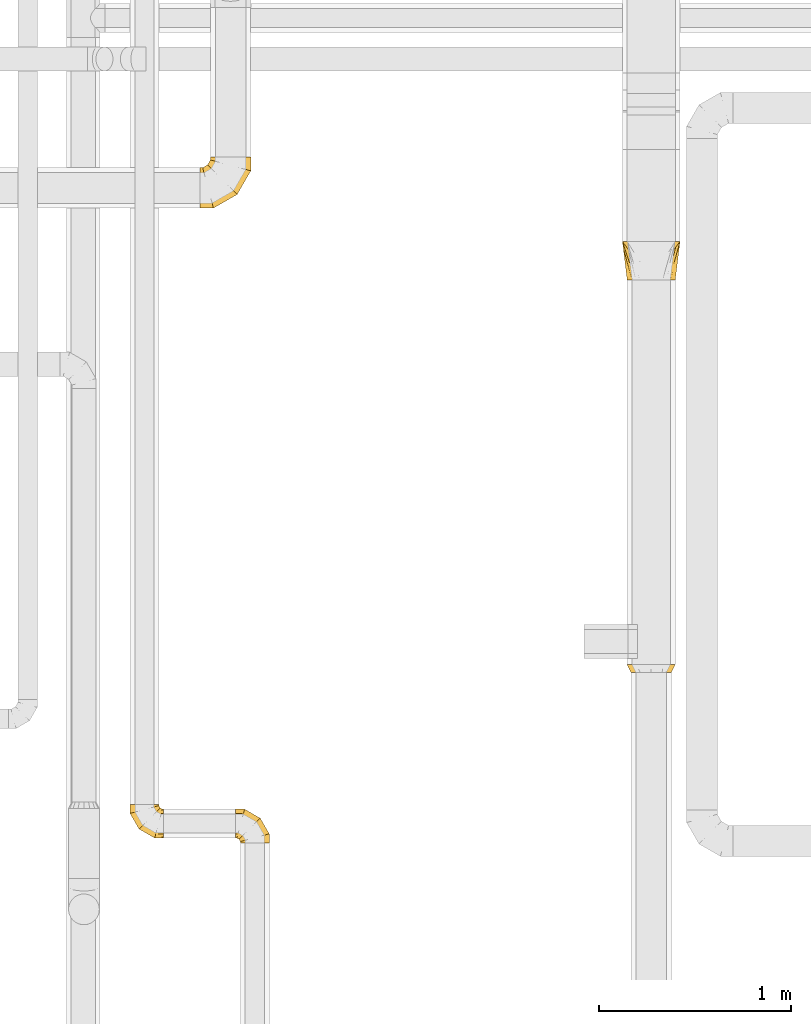
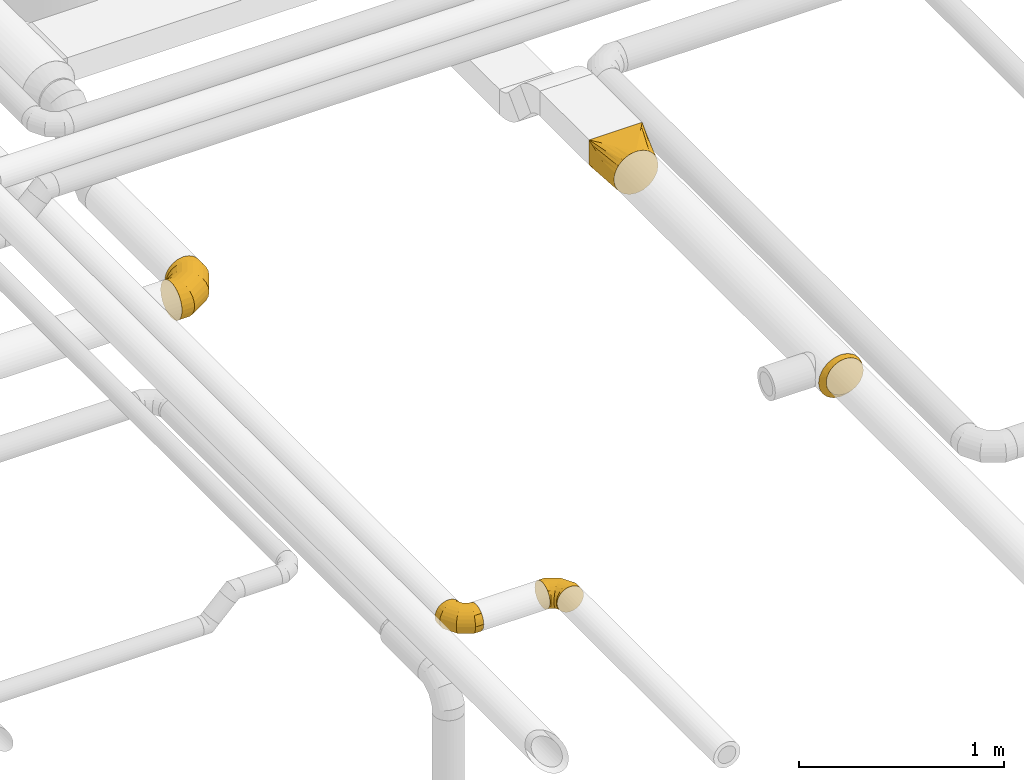
# One storey, part 20 of 92: 5 coverings.
"""IFC2X3 building model written with IfcOpenShell, lengths in millimetres."""

from ifc_helpers import new_model, entity, si_unit, converted_unit, derived_unit, direction, frame, origin, place, context, subcontext, project, spatial, faceted_brep, element, save


model = new_model("IFC2X3")

# Units and contexts
model_context = context("Model", 3, precision=0.01, world=origin(), true_north=direction((6.12303176911189e-17, 1.0)))
body_context = subcontext(model_context, "Body", "Model", "MODEL_VIEW")
ifc_project = project(units=[si_unit("LENGTHUNIT", "METRE", prefix="MILLI"), si_unit("AREAUNIT", "SQUARE_METRE"), si_unit("VOLUMEUNIT", "CUBIC_METRE"), converted_unit("PLANEANGLEUNIT", "DEGREE", entity("IfcRatioMeasure", 0.0174532925199433), si_unit("PLANEANGLEUNIT", "RADIAN"), dimensions=[0, 0, 0, 0, 0, 0, 0]), si_unit("MASSUNIT", "GRAM", prefix="KILO"), derived_unit("MASSDENSITYUNIT", [(si_unit("MASSUNIT", "GRAM", prefix="KILO"), 1), (si_unit("LENGTHUNIT", "METRE"), -3)]), derived_unit("MOMENTOFINERTIAUNIT", [(si_unit("LENGTHUNIT", "METRE"), 4)]), si_unit("TIMEUNIT", "SECOND"), si_unit("FREQUENCYUNIT", "HERTZ"), si_unit("THERMODYNAMICTEMPERATUREUNIT", "DEGREE_CELSIUS"), derived_unit("THERMALTRANSMITTANCEUNIT", [(si_unit("MASSUNIT", "GRAM", prefix="KILO"), 1), (si_unit("THERMODYNAMICTEMPERATUREUNIT", "KELVIN"), -1), (si_unit("TIMEUNIT", "SECOND"), -3)]), derived_unit("VOLUMETRICFLOWRATEUNIT", [(si_unit("LENGTHUNIT", "METRE"), 3), (si_unit("TIMEUNIT", "SECOND"), -1)]), derived_unit("MASSFLOWRATEUNIT", [(si_unit("MASSUNIT", "GRAM", prefix="KILO"), 1), (si_unit("TIMEUNIT", "SECOND"), -1)]), derived_unit("ROTATIONALFREQUENCYUNIT", [(si_unit("TIMEUNIT", "SECOND"), -1)]), si_unit("ELECTRICCURRENTUNIT", "AMPERE"), si_unit("ELECTRICVOLTAGEUNIT", "VOLT"), si_unit("POWERUNIT", "WATT"), si_unit("FORCEUNIT", "NEWTON", prefix="KILO"), si_unit("ILLUMINANCEUNIT", "LUX"), si_unit("LUMINOUSFLUXUNIT", "LUMEN"), si_unit("LUMINOUSINTENSITYUNIT", "CANDELA"), derived_unit("USERDEFINED", [(si_unit("MASSUNIT", "GRAM", prefix="KILO"), -1), (si_unit("LENGTHUNIT", "METRE"), -2), (si_unit("TIMEUNIT", "SECOND"), 3), (si_unit("LUMINOUSFLUXUNIT", "LUMEN"), 1)]), derived_unit("LINEARVELOCITYUNIT", [(si_unit("LENGTHUNIT", "METRE"), 1), (si_unit("TIMEUNIT", "SECOND"), -1)]), si_unit("PRESSUREUNIT", "PASCAL"), derived_unit("USERDEFINED", [(si_unit("LENGTHUNIT", "METRE"), -2), (si_unit("MASSUNIT", "GRAM", prefix="KILO"), 1), (si_unit("TIMEUNIT", "SECOND"), -2)]), derived_unit("LINEARFORCEUNIT", [(si_unit("MASSUNIT", "GRAM", prefix="KILO"), 1), (si_unit("LENGTHUNIT", "METRE"), 1), (si_unit("TIMEUNIT", "SECOND"), -2), (si_unit("LENGTHUNIT", "METRE"), -1)]), derived_unit("PLANARFORCEUNIT", [(si_unit("MASSUNIT", "GRAM", prefix="KILO"), 1), (si_unit("LENGTHUNIT", "METRE"), 1), (si_unit("TIMEUNIT", "SECOND"), -2), (si_unit("LENGTHUNIT", "METRE"), -2)])], contexts=[model_context])

# Site, building, storey
site_placement = place(None, origin())
site = spatial("IfcSite", under=ifc_project, at=site_placement, CompositionType="ELEMENT")
building_placement = place(site_placement, origin())
building = spatial("IfcBuilding", under=site, at=building_placement, CompositionType="ELEMENT")
storey_placement = place(building_placement, frame((0.0, 0.0, 4200.0)))
storey = spatial("IfcBuildingStorey", under=building, at=storey_placement, CompositionType="ELEMENT", Elevation=4200.0)

# Coverings
covering_1_placement = place(storey_placement, frame((63121.35, 7381.43, 3073.4)))
element("IfcCovering", 1, at=covering_1_placement, inside=storey, PredefinedType="INSULATION", context=body_context, shape_type="Brep", body=[
    faceted_brep([(150.0, 0.0, 251.6), (144.04, 0.0, 250.65), (138.08, 0.0, 249.71), (126.16, 0.0, 247.82), (111.37, 0.0, 245.48), (93.95, 0.0, 236.6), (76.53, 0.0, 227.72), (62.7, 0.0, 213.9), (48.87, 0.0, 200.07), (40.0, 0.0, 182.65), (31.12, 0.0, 165.22), (28.78, 0.0, 150.44), (26.89, 0.0, 138.52), (25.94, 0.0, 132.56), (25.0, 0.0, 126.6), (25.94, 0.0, 120.63), (26.89, 0.0, 114.67), (28.78, 0.0, 102.75), (31.12, 0.0, 87.97), (40.0, 0.0, 70.55), (48.87, 0.0, 53.12), (62.7, 0.0, 39.3), (76.53, 0.0, 25.47), (93.95, 0.0, 16.59), (111.37, 0.0, 7.71), (126.16, 0.0, 5.37), (138.08, 0.0, 3.48), (144.04, 0.0, 2.54), (150.0, 0.0, 1.6), (155.96, 0.0, 2.54), (161.92, 0.0, 3.48), (173.84, 0.0, 5.37), (188.63, 0.0, 7.71), (206.05, 0.0, 16.59), (223.47, 0.0, 25.47), (237.3, 0.0, 39.3), (251.13, 0.0, 53.12), (260.0, 0.0, 70.55), (268.88, 0.0, 87.97), (271.22, 0.0, 102.75), (273.11, 0.0, 114.67), (274.06, 0.0, 120.63), (275.0, 0.0, 126.6), (274.06, 0.0, 132.56), (273.11, 0.0, 138.52), (271.22, 0.0, 150.44), (268.88, 0.0, 165.22), (260.0, 0.0, 182.65), (251.13, 0.0, 200.07), (237.3, 0.0, 213.9), (223.47, 0.0, 227.72), (206.05, 0.0, 236.6), (188.63, 0.0, 245.48), (173.84, 0.0, 247.82), (161.92, 0.0, 249.71), (155.96, 0.0, 250.65), (300.0, 200.0, 251.6), (300.0, 200.0, 101.6), (0.0, 200.0, 101.6), (0.0, 200.0, 251.6), (221.91, 95.89, 49.54), (266.44, 100.0, 67.31), (280.48, 173.97, 88.58), (241.44, 121.91, 62.55), (260.96, 147.94, 75.57), (158.99, 11.99, 7.59), (167.98, 23.97, 13.58), (185.96, 47.94, 25.57), (203.94, 71.91, 37.55), (293.49, 147.94, 108.1), (290.24, 121.91, 111.36), (286.99, 95.89, 114.61), (283.99, 71.91, 117.61), (280.99, 47.94, 120.6), (278.0, 23.97, 123.6), (276.5, 11.99, 125.1), (296.75, 173.97, 104.85), (296.75, 173.97, 235.33), (293.49, 147.94, 219.06), (290.24, 121.91, 202.79), (286.99, 95.89, 186.52), (283.99, 71.91, 171.54), (280.99, 47.94, 156.56), (278.0, 23.97, 141.58), (276.5, 11.99, 134.09), (271.79, 100.0, 230.53), (260.96, 147.94, 251.6), (241.44, 121.91, 251.6), (221.91, 95.89, 251.6), (203.94, 71.91, 251.6), (185.96, 47.94, 251.6), (167.98, 23.97, 251.6), (158.99, 11.99, 251.6), (280.48, 173.97, 251.6), (19.52, 173.97, 251.6), (39.04, 147.94, 251.6), (58.56, 121.91, 251.6), (78.09, 95.89, 251.6), (96.06, 71.91, 251.6), (114.04, 47.94, 251.6), (132.02, 23.97, 251.6), (141.01, 11.99, 251.6), (33.56, 100.0, 235.88), (6.51, 147.94, 219.06), (9.76, 121.91, 202.79), (13.01, 95.89, 186.52), (16.01, 71.91, 171.54), (19.01, 47.94, 156.56), (22.0, 23.97, 141.58), (23.5, 11.99, 134.09), (3.25, 173.97, 235.33), (3.25, 173.97, 104.85), (6.51, 147.94, 108.1), (9.76, 121.91, 111.36), (13.01, 95.89, 114.61), (16.01, 71.91, 117.61), (19.01, 47.94, 120.6), (22.0, 23.97, 123.6), (23.5, 11.99, 125.1), (28.21, 100.0, 72.66), (39.04, 147.94, 75.57), (58.56, 121.91, 62.55), (78.09, 95.89, 49.54), (96.06, 71.91, 37.55), (114.04, 47.94, 25.57), (132.02, 23.97, 13.58), (141.01, 11.99, 7.59), (19.52, 173.97, 88.58)], [[[0, 1, 2, 3, 4, 5, 6, 7, 8, 9, 10, 11, 12, 13, 14, 15, 16, 17, 18, 19, 20, 21, 22, 23, 24, 25, 26, 27, 28, 29, 30, 31, 32, 33, 34, 35, 36, 37, 38, 39, 40, 41, 42, 43, 44, 45, 46, 47, 48, 49, 50, 51, 52, 53, 54, 55]], [[56, 57, 58, 59]], [[60, 33, 32]], [[57, 61, 62]], [[33, 60, 63, 64]], [[65, 66, 67, 68, 60, 32, 31, 30, 29, 28]], [[62, 61, 34]], [[37, 69, 70, 71]], [[64, 34, 33]], [[38, 71, 72, 73, 74, 75, 42, 41, 40, 39]], [[36, 76, 69]], [[71, 38, 37]], [[61, 76, 35]], [[34, 64, 62]], [[76, 36, 35]], [[34, 61, 35]], [[61, 57, 76]], [[69, 37, 36]], [[57, 56, 77, 78, 79, 80, 81, 82, 83, 84, 42, 75, 74, 73, 72, 71, 70, 69, 76]], [[80, 47, 46]], [[56, 85, 77]], [[47, 80, 79, 78]], [[84, 83, 82, 81, 80, 46, 45, 44, 43, 42]], [[77, 85, 48]], [[51, 86, 87, 88]], [[78, 48, 47]], [[52, 88, 89, 90, 91, 92, 0, 55, 54, 53]], [[50, 93, 86]], [[88, 52, 51]], [[85, 93, 49]], [[48, 78, 77]], [[93, 50, 49]], [[48, 85, 49]], [[85, 56, 93]], [[86, 51, 50]], [[56, 59, 94, 95, 96, 97, 98, 99, 100, 101, 0, 92, 91, 90, 89, 88, 87, 86, 93]], [[97, 5, 4]], [[59, 102, 94]], [[5, 97, 96, 95]], [[101, 100, 99, 98, 97, 4, 3, 2, 1, 0]], [[94, 102, 6]], [[9, 103, 104, 105]], [[95, 6, 5]], [[10, 105, 106, 107, 108, 109, 14, 13, 12, 11]], [[8, 110, 103]], [[105, 10, 9]], [[102, 110, 7]], [[6, 95, 94]], [[110, 8, 7]], [[6, 102, 7]], [[102, 59, 110]], [[103, 9, 8]], [[109, 108, 107, 106, 105, 104, 103, 110, 59, 58, 111, 112, 113, 114, 115, 116, 117, 118, 14]], [[114, 19, 18]], [[58, 119, 111]], [[19, 114, 113, 112]], [[118, 117, 116, 115, 114, 18, 17, 16, 15, 14]], [[111, 119, 20]], [[23, 120, 121, 122]], [[112, 20, 19]], [[24, 122, 123, 124, 125, 126, 28, 27, 26, 25]], [[22, 127, 120]], [[122, 24, 23]], [[119, 127, 21]], [[20, 112, 111]], [[127, 22, 21]], [[20, 119, 21]], [[119, 58, 127]], [[120, 23, 22]], [[58, 57, 62, 64, 63, 60, 68, 67, 66, 65, 28, 126, 125, 124, 123, 122, 121, 120, 127]]]),
])
covering_2_placement = place(storey_placement, frame((63144.76, 5341.43, 3073.4)))
element("IfcCovering", 2, at=covering_2_placement, inside=storey, PredefinedType="INSULATION", context=body_context, shape_type="Brep", body=[
    faceted_brep([(126.6, 40.0, 251.6), (165.22, 40.0, 245.48), (200.07, 40.0, 227.72), (227.72, 40.0, 200.07), (245.48, 40.0, 165.22), (251.6, 40.0, 126.6), (245.48, 40.0, 87.97), (227.72, 40.0, 53.12), (200.07, 40.0, 25.47), (165.22, 40.0, 7.71), (126.6, 40.0, 1.6), (87.97, 40.0, 7.71), (53.12, 40.0, 25.47), (25.47, 40.0, 53.12), (7.71, 40.0, 87.97), (1.6, 40.0, 126.6), (7.71, 40.0, 165.22), (25.47, 40.0, 200.07), (53.12, 40.0, 227.72), (87.97, 40.0, 245.48), (126.6, 0.0, 251.6), (94.15, 0.0, 246.46), (64.88, 0.0, 231.54), (41.65, 0.0, 208.31), (26.73, 0.0, 179.04), (21.6, 0.0, 146.6), (26.73, 0.0, 114.15), (41.65, 0.0, 84.88), (64.88, 0.0, 61.65), (94.15, 0.0, 46.73), (126.6, 0.0, 41.6), (159.04, 0.0, 46.73), (188.31, 0.0, 61.65), (211.54, 0.0, 84.88), (226.46, 0.0, 114.15), (231.6, 0.0, 146.6), (226.46, 0.0, 179.04), (211.54, 0.0, 208.31), (188.31, 0.0, 231.54), (159.04, 0.0, 246.46), (237.34, 20.0, 105.59), (241.46, 19.72, 136.74), (240.7, 18.21, 137.49), (229.06, 20.0, 84.39), (207.91, 20.0, 55.28), (178.8, 20.0, 34.13), (157.6, 20.0, 25.85), (126.6, 18.21, 23.38), (95.59, 20.0, 25.85), (74.39, 20.0, 34.13), (45.28, 20.0, 55.28), (24.13, 20.0, 84.39), (15.85, 20.0, 105.59), (12.49, 18.21, 137.49), (11.74, 19.72, 136.74), (24.13, 20.0, 188.8), (45.28, 20.0, 217.91), (15.85, 20.0, 167.6), (95.59, 20.0, 247.34), (74.39, 20.0, 239.06), (126.6, 19.72, 251.6), (178.8, 20.0, 239.06), (207.91, 20.0, 217.91), (157.6, 20.0, 247.34), (237.34, 20.0, 167.6), (229.06, 20.0, 188.8)], [[[0, 1, 2, 3, 4, 5, 6, 7, 8, 9, 10, 11, 12, 13, 14, 15, 16, 17, 18, 19]], [[20, 21, 22, 23, 24, 25, 26, 27, 28, 29, 30, 31, 32, 33, 34, 35, 36, 37, 38, 39]], [[40, 5, 41, 42, 35]], [[35, 34, 40]], [[34, 33, 43]], [[40, 34, 43]], [[43, 33, 44]], [[43, 44, 7]], [[6, 43, 7]], [[43, 6, 40]], [[44, 8, 7]], [[8, 45, 9]], [[45, 32, 31]], [[45, 31, 46]], [[30, 46, 31]], [[10, 9, 46]], [[8, 44, 45]], [[5, 40, 6]], [[30, 47, 10, 46]], [[32, 44, 33]], [[44, 32, 45]], [[46, 9, 45]], [[47, 30, 48, 10]], [[30, 29, 48]], [[29, 28, 49]], [[48, 29, 49]], [[49, 28, 50]], [[49, 50, 12]], [[11, 49, 12]], [[49, 11, 48]], [[50, 13, 12]], [[13, 51, 14]], [[51, 27, 26]], [[51, 26, 52]], [[25, 52, 26]], [[15, 14, 52]], [[13, 50, 51]], [[10, 48, 11]], [[25, 53, 54, 15, 52]], [[27, 50, 28]], [[50, 27, 51]], [[52, 14, 51]], [[55, 23, 56]], [[55, 16, 57]], [[24, 23, 55]], [[57, 24, 55]], [[54, 53, 25, 57, 15]], [[55, 56, 17]], [[16, 55, 17]], [[25, 24, 57]], [[56, 18, 17]], [[58, 19, 59]], [[59, 22, 21]], [[22, 56, 23]], [[18, 59, 19]], [[0, 19, 58]], [[18, 56, 59]], [[15, 57, 16]], [[59, 21, 58]], [[20, 58, 21]], [[56, 22, 59]], [[0, 58, 20, 60]], [[61, 38, 62]], [[61, 1, 63]], [[39, 38, 61]], [[63, 39, 61]], [[60, 20, 63, 0]], [[61, 62, 2]], [[1, 61, 2]], [[20, 39, 63]], [[62, 3, 2]], [[64, 4, 65]], [[65, 37, 36]], [[37, 62, 38]], [[3, 65, 4]], [[5, 4, 64]], [[3, 62, 65]], [[0, 63, 1]], [[65, 36, 64]], [[35, 64, 36]], [[62, 37, 65]], [[5, 64, 35, 42, 41]]]),
])
covering_3_placement = place(storey_placement, frame((60925.0, 7753.26, 2863.4)))
element("IfcCovering", 3, at=covering_3_placement, inside=storey, PredefinedType="INSULATION", context=body_context, shape_type="Brep", body=[
    faceted_brep([(160.0, 266.6, 211.6), (192.45, 266.6, 206.46), (221.72, 266.6, 191.54), (244.95, 266.6, 168.31), (259.86, 266.6, 139.04), (265.0, 266.6, 106.6), (259.86, 266.6, 74.15), (244.95, 266.6, 44.88), (221.72, 266.6, 21.65), (192.45, 266.6, 6.73), (160.0, 266.6, 1.6), (127.55, 266.6, 6.73), (98.28, 266.6, 21.65), (75.05, 266.6, 44.88), (60.14, 266.6, 74.15), (55.0, 266.6, 106.6), (60.14, 266.6, 139.04), (75.05, 266.6, 168.31), (98.28, 266.6, 191.54), (127.55, 266.6, 206.46), (0.0, 15.66, 54.1), (0.0, 5.17, 79.42), (0.0, 1.6, 106.6), (0.0, 5.17, 133.77), (0.0, 15.66, 159.1), (0.0, 32.35, 180.84), (0.0, 54.1, 197.53), (0.0, 79.42, 208.02), (0.0, 106.6, 211.6), (0.0, 133.77, 208.02), (0.0, 159.1, 197.53), (0.0, 180.84, 180.84), (0.0, 197.53, 159.1), (0.0, 208.02, 133.77), (0.0, 211.6, 106.6), (0.0, 208.02, 79.42), (0.0, 197.53, 54.1), (0.0, 180.84, 32.35), (0.0, 159.1, 15.66), (0.0, 133.77, 5.17), (0.0, 106.6, 1.6), (0.0, 79.42, 5.17), (0.0, 54.1, 15.66), (0.0, 32.35, 32.35), (71.01, 1.6, 106.6), (70.05, 5.17, 133.77), (67.24, 15.66, 159.1), (62.77, 32.35, 180.84), (56.94, 54.1, 197.53), (50.15, 79.42, 208.02), (42.87, 106.6, 211.6), (35.59, 133.77, 208.02), (28.8, 159.1, 197.53), (22.98, 180.84, 180.84), (18.51, 197.53, 159.1), (15.7, 208.02, 133.77), (14.74, 211.6, 106.6), (15.7, 208.02, 79.42), (18.51, 197.53, 54.1), (22.98, 180.84, 32.35), (35.59, 133.77, 5.17), (42.87, 106.6, 1.6), (28.8, 159.1, 15.66), (50.15, 79.42, 5.17), (56.94, 54.1, 15.66), (62.77, 32.35, 32.35), (67.24, 15.66, 54.1), (70.05, 5.17, 79.42), (193.99, 72.6, 106.6), (191.37, 75.22, 133.77), (183.7, 82.9, 159.1), (171.48, 95.12, 180.84), (155.56, 111.03, 197.53), (137.02, 129.57, 208.02), (117.13, 149.47, 211.6), (97.23, 169.36, 208.02), (78.7, 187.9, 197.53), (62.78, 203.82, 180.84), (50.56, 216.03, 159.1), (42.88, 223.71, 133.77), (40.26, 226.33, 106.6), (42.88, 223.71, 79.42), (50.56, 216.03, 54.1), (62.78, 203.82, 32.35), (97.23, 169.36, 5.17), (117.13, 149.47, 1.6), (78.7, 187.9, 15.66), (137.02, 129.57, 5.17), (155.56, 111.03, 15.66), (171.48, 95.12, 32.35), (183.7, 82.9, 54.1), (191.37, 75.22, 79.42), (265.0, 195.59, 106.6), (261.42, 196.55, 133.77), (250.93, 199.36, 159.1), (234.25, 203.83, 180.84), (212.5, 209.66, 197.53), (187.18, 216.44, 208.02), (160.0, 223.72, 211.6), (132.82, 231.01, 208.02), (107.5, 237.79, 197.53), (85.75, 243.62, 180.84), (69.07, 248.09, 159.1), (58.58, 250.9, 133.77), (55.0, 251.86, 106.6), (58.58, 250.9, 79.42), (69.07, 248.09, 54.1), (85.75, 243.62, 32.35), (132.82, 231.01, 5.17), (160.0, 223.72, 1.6), (107.5, 237.79, 15.66), (187.18, 216.44, 5.17), (212.5, 209.66, 15.66), (234.25, 203.83, 32.35), (250.93, 199.36, 54.1), (261.42, 196.55, 79.42)], [[[0, 1, 2, 3, 4, 5, 6, 7, 8, 9, 10, 11, 12, 13, 14, 15, 16, 17, 18, 19]], [[20, 21, 22, 23, 24, 25, 26, 27, 28, 29, 30, 31, 32, 33, 34, 35, 36, 37, 38, 39, 40, 41, 42, 43]], [[22, 44, 45, 23]], [[23, 45, 46, 24]], [[24, 46, 47, 25]], [[25, 47, 48, 26]], [[26, 48, 49, 27]], [[50, 28, 27, 49]], [[51, 52, 30, 29]], [[50, 51, 29, 28]], [[53, 31, 30, 52]], [[54, 55, 33, 32]], [[54, 32, 31, 53]], [[56, 34, 33, 55]], [[57, 58, 36, 35]], [[56, 57, 35, 34]], [[37, 36, 58, 59]], [[60, 61, 40, 39]], [[62, 60, 39, 38]], [[59, 62, 38, 37]], [[41, 40, 61, 63]], [[42, 41, 63, 64]], [[64, 65, 43, 42]], [[21, 20, 66, 67]], [[22, 21, 67, 44]], [[65, 66, 20, 43]], [[45, 44, 68, 69]], [[46, 45, 69, 70]], [[70, 71, 47, 46]], [[48, 47, 71, 72]], [[49, 48, 72, 73]], [[50, 49, 73, 74]], [[75, 76, 52, 51]], [[74, 75, 51, 50]], [[53, 52, 76, 77]], [[78, 79, 55, 54]], [[77, 78, 54, 53]], [[56, 55, 79, 80]], [[81, 82, 58, 57]], [[80, 81, 57, 56]], [[59, 58, 82, 83]], [[84, 85, 61, 60]], [[86, 84, 60, 62]], [[83, 86, 62, 59]], [[63, 61, 85, 87]], [[64, 63, 87, 88]], [[65, 64, 88, 89]], [[67, 66, 90, 91]], [[44, 67, 91, 68]], [[89, 90, 66, 65]], [[69, 68, 92, 93]], [[70, 69, 93, 94]], [[94, 95, 71, 70]], [[72, 71, 95, 96]], [[73, 72, 96, 97]], [[74, 73, 97, 98]], [[99, 100, 76, 75]], [[98, 99, 75, 74]], [[77, 76, 100, 101]], [[102, 103, 79, 78]], [[101, 102, 78, 77]], [[80, 79, 103, 104]], [[105, 106, 82, 81]], [[104, 105, 81, 80]], [[83, 82, 106, 107]], [[108, 109, 85, 84]], [[110, 108, 84, 86]], [[107, 110, 86, 83]], [[87, 85, 109, 111]], [[88, 87, 111, 112]], [[89, 88, 112, 113]], [[91, 90, 114, 115]], [[68, 91, 115, 92]], [[113, 114, 90, 89]], [[93, 5, 4]], [[94, 4, 3]], [[5, 93, 92]], [[93, 4, 94]], [[3, 95, 94]], [[96, 2, 1]], [[97, 1, 0]], [[95, 2, 96]], [[96, 1, 97]], [[0, 98, 97]], [[2, 95, 3]], [[99, 0, 19]], [[100, 19, 18]], [[99, 98, 0]], [[100, 99, 19]], [[18, 101, 100]], [[102, 17, 16]], [[103, 16, 15]], [[102, 101, 17]], [[104, 103, 15]], [[102, 16, 103]], [[17, 101, 18]], [[105, 15, 14]], [[106, 14, 13]], [[105, 104, 15]], [[106, 105, 14]], [[13, 107, 106]], [[110, 12, 11]], [[108, 11, 10]], [[110, 107, 12]], [[109, 108, 10]], [[110, 11, 108]], [[12, 107, 13]], [[9, 8, 112]], [[10, 9, 111]], [[10, 111, 109]], [[111, 9, 112]], [[8, 113, 112]], [[114, 7, 6]], [[115, 6, 5]], [[113, 7, 114]], [[115, 114, 6]], [[92, 115, 5]], [[7, 113, 8]]]),
])
covering_4_placement = place(storey_placement, frame((60560.54, 4478.9, 3073.4)))
element("IfcCovering", 4, at=covering_4_placement, inside=storey, PredefinedType="INSULATION", context=body_context, shape_type="Brep", body=[
    faceted_brep([(176.6, 7.3, 105.3), (176.6, 4.45, 90.95), (176.6, 1.6, 76.6), (176.6, 4.45, 62.24), (176.6, 7.3, 47.89), (176.6, 15.43, 35.73), (176.6, 23.56, 23.56), (176.6, 35.73, 15.43), (176.6, 47.89, 7.3), (176.6, 62.24, 4.45), (176.6, 76.6, 1.6), (176.6, 90.95, 4.45), (176.6, 105.3, 7.3), (176.6, 117.46, 15.43), (176.6, 129.63, 23.56), (176.6, 137.76, 35.73), (176.6, 145.89, 47.89), (176.6, 148.74, 62.24), (176.6, 150.17, 69.42), (176.6, 151.6, 76.6), (176.6, 150.17, 83.77), (176.6, 148.74, 90.95), (176.6, 145.89, 105.3), (176.6, 137.76, 117.46), (176.6, 129.63, 129.63), (176.6, 117.46, 137.76), (176.6, 105.3, 145.89), (176.6, 90.95, 148.74), (176.6, 76.6, 151.6), (176.6, 62.24, 148.74), (176.6, 47.89, 145.89), (176.6, 35.73, 137.76), (176.6, 23.56, 129.63), (176.6, 15.43, 117.46), (4.15, 176.6, 57.18), (1.6, 176.6, 76.6), (4.15, 176.6, 96.01), (11.64, 176.6, 114.1), (23.56, 176.6, 129.63), (39.1, 176.6, 141.55), (57.18, 176.6, 149.04), (76.6, 176.6, 151.6), (96.01, 176.6, 149.04), (114.1, 176.6, 141.55), (129.63, 176.6, 129.63), (141.55, 176.6, 114.1), (149.04, 176.6, 96.01), (151.6, 176.6, 76.6), (149.04, 176.6, 57.18), (141.55, 176.6, 39.1), (129.63, 176.6, 23.56), (114.1, 176.6, 11.64), (96.01, 176.6, 4.15), (76.6, 176.6, 1.6), (57.18, 176.6, 4.15), (39.1, 176.6, 11.64), (23.56, 176.6, 23.56), (11.64, 176.6, 39.1), (1.6, 129.7, 76.6), (4.15, 130.39, 96.01), (11.64, 132.4, 114.1), (23.56, 135.59, 129.63), (39.1, 139.75, 141.55), (57.18, 144.6, 149.04), (76.6, 149.8, 151.6), (96.01, 155.0, 149.04), (114.1, 159.85, 141.55), (129.63, 164.01, 129.63), (141.55, 167.2, 114.1), (149.04, 169.21, 96.01), (151.6, 169.9, 76.6), (149.04, 169.21, 57.18), (141.55, 167.2, 39.1), (129.63, 164.01, 23.56), (96.01, 155.0, 4.15), (76.6, 149.8, 1.6), (114.1, 159.85, 11.64), (57.18, 144.6, 4.15), (39.1, 139.75, 11.64), (23.56, 135.59, 23.56), (11.64, 132.4, 39.1), (4.15, 130.39, 57.18), (48.49, 48.49, 76.6), (50.36, 50.36, 96.01), (55.84, 55.84, 114.1), (64.57, 64.57, 129.63), (75.94, 75.94, 141.55), (89.18, 89.18, 149.04), (103.39, 103.39, 151.6), (117.6, 117.6, 149.04), (130.84, 130.84, 141.55), (142.21, 142.21, 129.63), (150.94, 150.94, 114.1), (156.42, 156.42, 96.01), (158.29, 158.29, 76.6), (156.42, 156.42, 57.18), (150.94, 150.94, 39.1), (142.21, 142.21, 23.56), (117.6, 117.6, 4.15), (103.39, 103.39, 1.6), (130.84, 130.84, 11.64), (89.18, 89.18, 4.15), (75.94, 75.94, 11.64), (64.57, 64.57, 23.56), (55.84, 55.84, 39.1), (50.36, 50.36, 57.18), (129.7, 1.6, 76.6), (130.39, 4.15, 96.01), (132.4, 11.64, 114.1), (135.59, 23.56, 129.63), (139.75, 39.1, 141.55), (144.6, 57.18, 149.04), (149.8, 76.6, 151.6), (155.0, 96.01, 149.04), (159.85, 114.1, 141.55), (164.01, 129.63, 129.63), (167.2, 141.55, 114.1), (168.21, 145.29, 105.05), (169.21, 149.04, 96.01), (169.55, 150.32, 86.3), (169.9, 151.6, 76.6), (169.21, 149.04, 57.18), (168.21, 145.29, 48.14), (167.2, 141.55, 39.1), (169.55, 150.32, 66.89), (164.01, 129.63, 23.56), (155.0, 96.01, 4.15), (149.8, 76.6, 1.6), (159.85, 114.1, 11.64), (144.6, 57.18, 4.15), (139.75, 39.1, 11.64), (135.59, 23.56, 23.56), (132.4, 11.64, 39.1), (130.39, 4.15, 57.18)], [[[0, 1, 2, 3, 4, 5, 6, 7, 8, 9, 10, 11, 12, 13, 14, 15, 16, 17, 18, 19, 20, 21, 22, 23, 24, 25, 26, 27, 28, 29, 30, 31, 32, 33]], [[34, 35, 36, 37, 38, 39, 40, 41, 42, 43, 44, 45, 46, 47, 48, 49, 50, 51, 52, 53, 54, 55, 56, 57]], [[35, 58, 59, 36]], [[36, 59, 60, 37]], [[37, 60, 61, 38]], [[39, 62, 63, 40]], [[40, 63, 64, 41]], [[38, 61, 62, 39]], [[65, 66, 43, 42]], [[64, 65, 42, 41]], [[67, 44, 43, 66]], [[68, 69, 46, 45]], [[68, 45, 44, 67]], [[70, 47, 46, 69]], [[71, 72, 49, 48]], [[70, 71, 48, 47]], [[50, 49, 72, 73]], [[74, 75, 53, 52]], [[76, 74, 52, 51]], [[73, 76, 51, 50]], [[55, 54, 77, 78]], [[56, 55, 78, 79]], [[53, 75, 77, 54]], [[34, 57, 80, 81]], [[35, 34, 81, 58]], [[79, 80, 57, 56]], [[58, 82, 83, 59]], [[60, 59, 83, 84]], [[84, 85, 61, 60]], [[62, 61, 85, 86]], [[63, 62, 86, 87]], [[64, 63, 87, 88]], [[89, 90, 66, 65]], [[88, 89, 65, 64]], [[67, 66, 90, 91]], [[92, 93, 69, 68]], [[91, 92, 68, 67]], [[70, 69, 93, 94]], [[95, 96, 72, 71]], [[94, 95, 71, 70]], [[73, 72, 96, 97]], [[98, 99, 75, 74]], [[100, 98, 74, 76]], [[97, 100, 76, 73]], [[77, 75, 99, 101]], [[78, 77, 101, 102]], [[79, 78, 102, 103]], [[81, 80, 104, 105]], [[58, 81, 105, 82]], [[103, 104, 80, 79]], [[82, 106, 107, 83]], [[84, 83, 107, 108]], [[108, 109, 85, 84]], [[86, 85, 109, 110]], [[87, 86, 110, 111]], [[88, 87, 111, 112]], [[113, 114, 90, 89]], [[112, 113, 89, 88]], [[91, 90, 114, 115]], [[93, 92, 116, 117, 118]], [[115, 116, 92, 91]], [[94, 93, 118, 119, 120]], [[95, 121, 122, 123, 96]], [[94, 120, 124, 121, 95]], [[97, 96, 123, 125]], [[126, 127, 99, 98]], [[128, 126, 98, 100]], [[125, 128, 100, 97]], [[101, 99, 127, 129]], [[102, 101, 129, 130]], [[103, 102, 130, 131]], [[105, 104, 132, 133]], [[82, 105, 133, 106]], [[131, 132, 104, 103]], [[106, 1, 107]], [[111, 30, 29]], [[1, 106, 2]], [[32, 109, 33]], [[108, 0, 33]], [[107, 0, 108]], [[31, 30, 110]], [[108, 33, 109]], [[31, 109, 32]], [[28, 112, 29]], [[1, 0, 107]], [[112, 111, 29]], [[110, 30, 111]], [[109, 31, 110]], [[113, 28, 27, 26]], [[24, 115, 25]], [[119, 21, 20]], [[114, 26, 25]], [[114, 113, 26]], [[120, 20, 19]], [[114, 25, 115]], [[28, 113, 112]], [[120, 119, 20]], [[21, 119, 118]], [[22, 118, 117, 116]], [[24, 23, 115]], [[115, 23, 116]], [[118, 22, 21]], [[116, 23, 22]], [[121, 17, 16]], [[15, 14, 125]], [[16, 123, 122, 121]], [[18, 17, 124]], [[18, 120, 19]], [[125, 123, 15]], [[13, 125, 14]], [[126, 12, 11, 10]], [[125, 13, 128]], [[120, 18, 124]], [[126, 128, 12]], [[126, 10, 127]], [[17, 121, 124]], [[123, 16, 15]], [[13, 12, 128]], [[127, 9, 129]], [[6, 131, 7]], [[130, 8, 7]], [[129, 8, 130]], [[5, 131, 6]], [[9, 8, 129]], [[130, 7, 131]], [[9, 127, 10]], [[133, 4, 3]], [[131, 5, 132]], [[2, 106, 3]], [[4, 133, 132]], [[106, 133, 3]], [[5, 4, 132]]]),
])
covering_5_placement = place(storey_placement, frame((61110.97, 4455.49, 3073.4)))
element("IfcCovering", 5, at=covering_5_placement, inside=storey, PredefinedType="INSULATION", context=body_context, shape_type="Brep", body=[
    faceted_brep([(0.0, 169.29, 105.3), (0.0, 172.15, 90.95), (0.0, 175.0, 76.6), (0.0, 172.15, 62.24), (0.0, 169.29, 47.89), (0.0, 161.16, 35.73), (0.0, 153.03, 23.56), (0.0, 140.87, 15.43), (0.0, 128.7, 7.3), (0.0, 114.35, 4.45), (0.0, 100.0, 1.6), (0.0, 85.65, 4.45), (0.0, 71.3, 7.3), (0.0, 59.13, 15.43), (0.0, 46.97, 23.56), (0.0, 38.84, 35.73), (0.0, 30.71, 47.89), (0.0, 27.85, 62.24), (0.0, 26.43, 69.42), (0.0, 25.0, 76.6), (0.0, 26.43, 83.77), (0.0, 27.85, 90.95), (0.0, 30.71, 105.3), (0.0, 38.84, 117.46), (0.0, 46.97, 129.63), (0.0, 59.13, 137.76), (0.0, 71.3, 145.89), (0.0, 85.65, 148.74), (0.0, 100.0, 151.6), (0.0, 114.35, 148.74), (0.0, 128.7, 145.89), (0.0, 140.87, 137.76), (0.0, 153.03, 129.63), (0.0, 161.16, 117.46), (172.44, 0.0, 57.18), (175.0, 0.0, 76.6), (172.44, 0.0, 96.01), (164.95, 0.0, 114.1), (153.03, 0.0, 129.63), (137.5, 0.0, 141.55), (119.41, 0.0, 149.04), (100.0, 0.0, 151.6), (80.59, 0.0, 149.04), (62.5, 0.0, 141.55), (46.97, 0.0, 129.63), (35.05, 0.0, 114.1), (27.56, 0.0, 96.01), (25.0, 0.0, 76.6), (27.56, 0.0, 57.18), (35.05, 0.0, 39.1), (46.97, 0.0, 23.56), (62.5, 0.0, 11.64), (80.59, 0.0, 4.15), (100.0, 0.0, 1.6), (119.41, 0.0, 4.15), (137.5, 0.0, 11.64), (153.03, 0.0, 23.56), (164.95, 0.0, 39.1), (175.0, 46.89, 76.6), (172.44, 46.21, 96.01), (164.95, 44.2, 114.1), (153.03, 41.01, 129.63), (137.5, 36.84, 141.55), (119.41, 32.0, 149.04), (100.0, 26.79, 151.6), (80.59, 21.59, 149.04), (62.5, 16.75, 141.55), (46.97, 12.58, 129.63), (35.05, 9.39, 114.1), (27.56, 7.38, 96.01), (25.0, 6.7, 76.6), (27.56, 7.38, 57.18), (35.05, 9.39, 39.1), (46.97, 12.58, 23.56), (80.59, 21.59, 4.15), (100.0, 26.79, 1.6), (62.5, 16.75, 11.64), (119.41, 32.0, 4.15), (137.5, 36.84, 11.64), (153.03, 41.01, 23.56), (164.95, 44.2, 39.1), (172.44, 46.21, 57.18), (128.11, 128.11, 76.6), (126.24, 126.24, 96.01), (120.75, 120.75, 114.1), (112.03, 112.03, 129.63), (100.66, 100.66, 141.55), (87.42, 87.42, 149.04), (73.21, 73.21, 151.6), (58.99, 58.99, 149.04), (45.75, 45.75, 141.55), (34.38, 34.38, 129.63), (25.66, 25.66, 114.1), (20.17, 20.17, 96.01), (18.3, 18.3, 76.6), (20.17, 20.17, 57.18), (25.66, 25.66, 39.1), (34.38, 34.38, 23.56), (58.99, 58.99, 4.15), (73.21, 73.21, 1.6), (45.75, 45.75, 11.64), (87.42, 87.42, 4.15), (100.66, 100.66, 11.64), (112.03, 112.03, 23.56), (120.75, 120.75, 39.1), (126.24, 126.24, 57.18), (46.89, 175.0, 76.6), (46.21, 172.44, 96.01), (44.2, 164.95, 114.1), (41.01, 153.03, 129.63), (36.84, 137.5, 141.55), (32.0, 119.41, 149.04), (26.79, 100.0, 151.6), (21.59, 80.59, 149.04), (16.75, 62.5, 141.55), (12.58, 46.97, 129.63), (9.39, 35.05, 114.1), (8.39, 31.3, 105.05), (7.38, 27.56, 96.01), (7.04, 26.28, 86.3), (6.7, 25.0, 76.6), (7.38, 27.56, 57.18), (8.39, 31.3, 48.14), (9.39, 35.05, 39.1), (7.04, 26.28, 66.89), (12.58, 46.97, 23.56), (21.59, 80.59, 4.15), (26.79, 100.0, 1.6), (16.75, 62.5, 11.64), (32.0, 119.41, 4.15), (36.84, 137.5, 11.64), (41.01, 153.03, 23.56), (44.2, 164.95, 39.1), (46.21, 172.44, 57.18)], [[[0, 1, 2, 3, 4, 5, 6, 7, 8, 9, 10, 11, 12, 13, 14, 15, 16, 17, 18, 19, 20, 21, 22, 23, 24, 25, 26, 27, 28, 29, 30, 31, 32, 33]], [[34, 35, 36, 37, 38, 39, 40, 41, 42, 43, 44, 45, 46, 47, 48, 49, 50, 51, 52, 53, 54, 55, 56, 57]], [[35, 58, 59, 36]], [[36, 59, 60, 37]], [[37, 60, 61, 38]], [[39, 62, 63, 40]], [[40, 63, 64, 41]], [[38, 61, 62, 39]], [[65, 66, 43, 42]], [[64, 65, 42, 41]], [[67, 44, 43, 66]], [[68, 69, 46, 45]], [[68, 45, 44, 67]], [[70, 47, 46, 69]], [[71, 72, 49, 48]], [[70, 71, 48, 47]], [[50, 49, 72, 73]], [[74, 75, 53, 52]], [[76, 74, 52, 51]], [[73, 76, 51, 50]], [[55, 54, 77, 78]], [[56, 55, 78, 79]], [[53, 75, 77, 54]], [[34, 57, 80, 81]], [[35, 34, 81, 58]], [[79, 80, 57, 56]], [[58, 82, 83, 59]], [[60, 59, 83, 84]], [[84, 85, 61, 60]], [[62, 61, 85, 86]], [[63, 62, 86, 87]], [[64, 63, 87, 88]], [[89, 90, 66, 65]], [[88, 89, 65, 64]], [[67, 66, 90, 91]], [[92, 93, 69, 68]], [[91, 92, 68, 67]], [[70, 69, 93, 94]], [[95, 96, 72, 71]], [[94, 95, 71, 70]], [[73, 72, 96, 97]], [[98, 99, 75, 74]], [[100, 98, 74, 76]], [[97, 100, 76, 73]], [[77, 75, 99, 101]], [[78, 77, 101, 102]], [[79, 78, 102, 103]], [[81, 80, 104, 105]], [[58, 81, 105, 82]], [[103, 104, 80, 79]], [[82, 106, 107, 83]], [[84, 83, 107, 108]], [[108, 109, 85, 84]], [[86, 85, 109, 110]], [[87, 86, 110, 111]], [[88, 87, 111, 112]], [[113, 114, 90, 89]], [[112, 113, 89, 88]], [[91, 90, 114, 115]], [[93, 92, 116, 117, 118]], [[115, 116, 92, 91]], [[94, 93, 118, 119, 120]], [[95, 121, 122, 123, 96]], [[94, 120, 124, 121, 95]], [[97, 96, 123, 125]], [[126, 127, 99, 98]], [[128, 126, 98, 100]], [[125, 128, 100, 97]], [[101, 99, 127, 129]], [[102, 101, 129, 130]], [[103, 102, 130, 131]], [[105, 104, 132, 133]], [[82, 105, 133, 106]], [[131, 132, 104, 103]], [[106, 1, 107]], [[111, 30, 29]], [[1, 106, 2]], [[32, 109, 33]], [[108, 0, 33]], [[107, 0, 108]], [[31, 30, 110]], [[108, 33, 109]], [[31, 109, 32]], [[28, 112, 29]], [[1, 0, 107]], [[112, 111, 29]], [[110, 30, 111]], [[109, 31, 110]], [[113, 28, 27, 26]], [[24, 115, 25]], [[119, 21, 20]], [[114, 26, 25]], [[114, 113, 26]], [[120, 20, 19]], [[114, 25, 115]], [[28, 113, 112]], [[120, 119, 20]], [[21, 119, 118]], [[22, 118, 117, 116]], [[24, 23, 115]], [[115, 23, 116]], [[118, 22, 21]], [[116, 23, 22]], [[121, 17, 16]], [[15, 14, 125]], [[16, 123, 122, 121]], [[18, 17, 124]], [[18, 120, 19]], [[125, 123, 15]], [[13, 125, 14]], [[126, 12, 11, 10]], [[125, 13, 128]], [[120, 18, 124]], [[126, 128, 12]], [[126, 10, 127]], [[17, 121, 124]], [[123, 16, 15]], [[13, 12, 128]], [[127, 9, 129]], [[6, 131, 7]], [[130, 8, 7]], [[129, 8, 130]], [[5, 131, 6]], [[9, 8, 129]], [[130, 7, 131]], [[9, 127, 10]], [[133, 4, 3]], [[131, 5, 132]], [[2, 106, 3]], [[4, 133, 132]], [[106, 133, 3]], [[5, 4, 132]]]),
])

save(model, "model.ifc")
